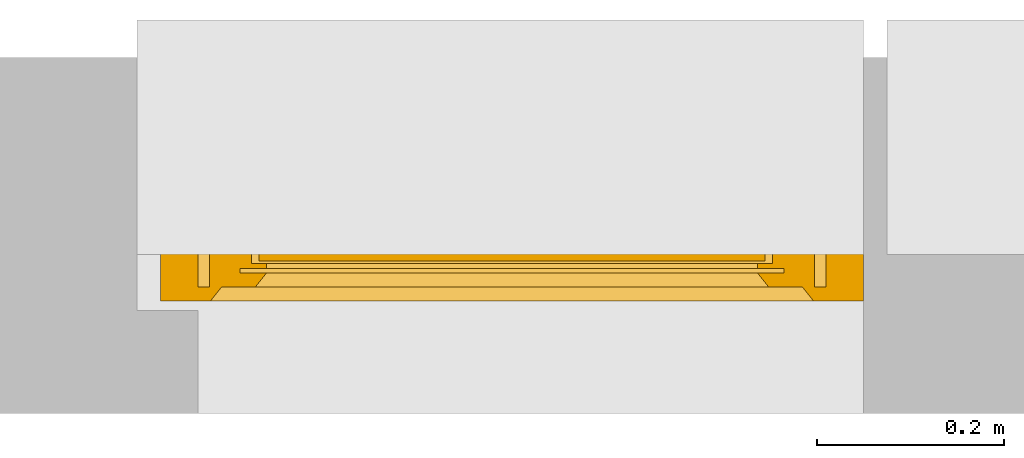
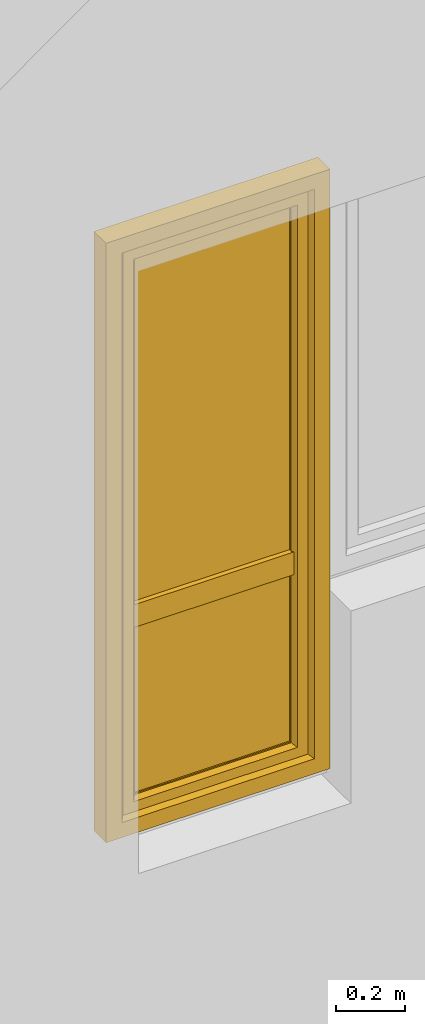
# One storey, part 3 of 4: 1 window.
"""IFC2X3 building model written with IfcOpenShell, lengths in millimetres."""

from ifc_helpers import new_model, entity, si_unit, converted_unit, derived_unit, direction, frame, origin, place, context, subcontext, project, spatial, faceted_brep, source, transform, mapped, material, material_list, type_object, type_shapes, element, save


model = new_model("IFC2X3")

# Units and contexts
model_context = context("Model", 3, precision=0.01, world=origin(), true_north=direction((6.12303176911189e-17, 1.0)))
context_of_model = context(None, 3, precision=0.01, world=origin(), true_north=direction((6.12303176911189e-17, 1.0)))
body_context = subcontext(model_context, "Body", "Model", "MODEL_VIEW")
ifc_project = project(units=[si_unit("LENGTHUNIT", "METRE", prefix="MILLI"), si_unit("AREAUNIT", "SQUARE_METRE"), si_unit("VOLUMEUNIT", "CUBIC_METRE"), converted_unit("PLANEANGLEUNIT", "DEGREE", entity("IfcRatioMeasure", 0.0174532925199433), si_unit("PLANEANGLEUNIT", "RADIAN"), dimensions=[0, 0, 0, 0, 0, 0, 0]), si_unit("MASSUNIT", "GRAM", prefix="KILO"), si_unit("TIMEUNIT", "SECOND"), si_unit("FREQUENCYUNIT", "HERTZ"), si_unit("THERMODYNAMICTEMPERATUREUNIT", "DEGREE_CELSIUS"), derived_unit("THERMALTRANSMITTANCEUNIT", [(si_unit("MASSUNIT", "GRAM", prefix="KILO"), 1), (si_unit("THERMODYNAMICTEMPERATUREUNIT", "KELVIN"), -1), (si_unit("TIMEUNIT", "SECOND"), -3)]), derived_unit("VOLUMETRICFLOWRATEUNIT", [(si_unit("LENGTHUNIT", "METRE"), 3), (si_unit("TIMEUNIT", "SECOND"), -1)]), si_unit("ELECTRICCURRENTUNIT", "AMPERE"), si_unit("ELECTRICVOLTAGEUNIT", "VOLT"), si_unit("POWERUNIT", "WATT"), si_unit("FORCEUNIT", "NEWTON", prefix="KILO"), si_unit("ILLUMINANCEUNIT", "LUX"), si_unit("LUMINOUSFLUXUNIT", "LUMEN"), si_unit("LUMINOUSINTENSITYUNIT", "CANDELA"), si_unit("PRESSUREUNIT", "PASCAL")], contexts=[model_context, context_of_model])

# Site, building, storey
site_placement = place(None, origin())
site = spatial("IfcSite", under=ifc_project, at=site_placement, CompositionType="ELEMENT")
building_placement = place(site_placement, origin())
building = spatial("IfcBuilding", under=site, at=building_placement, CompositionType="ELEMENT")
storey_placement = place(building_placement, origin())
storey = spatial("IfcBuildingStorey", under=building, at=storey_placement, CompositionType="ELEMENT", Elevation=0.0)

# Window
ifc_material_1 = material()
ifc_material_2 = material()
ifc_material_3 = material(Name="Rubber, Black")
ifc_material_4 = material()
ifc_material_5 = material()
ifc_material_list_1 = material_list([ifc_material_1, ifc_material_2, ifc_material_3, ifc_material_4, ifc_material_5])
ifc_material_list_2 = material_list([ifc_material_1, ifc_material_2, ifc_material_3, ifc_material_4, ifc_material_5])
window_style = type_object("IfcWindowStyle", ConstructionType="NOTDEFINED", OperationType="NOTDEFINED", ParameterTakesPrecedence=False, Sizeable=False, material=ifc_material_list_2)
shared_shape = source(origin(), body_context, "Body", "Brep", [
    faceted_brep([(-288.0, -95.0, 1078.0), (-288.0, -95.0, 1042.0), (-288.0, -87.0, 1042.0), (-288.0, -87.0, 1078.0), (-288.843235975199, -87.0, 1082.78534851355), (-288.422218385848, -95.0, 1080.39432433825), (-293.138446626751, -95.0, 1088.56228263263), (-294.997972538787, -87.0, 1090.12318487168), (-295.00101380401, -95.0, 1090.12494091651), (-310.861553373234, -87.0, 1088.56228263264), (-309.002027461198, -95.0, 1090.12318487168), (-308.998986195976, -87.0, 1090.12494091651), (-291.273622272693, -87.0, 1086.99693396951), (-291.275879449492, -95.0, 1086.99962434876), (-290.060158110598, -95.0, 1084.89413651262), (-299.567004156991, -87.0, 1091.78696961731), (-299.570462631182, -95.0, 1091.78757948931), (-297.285738217596, -95.0, 1090.95626020291), (-293.13579740574, -87.0, 1088.5600594206), (-288.844436771704, -95.0, 1082.78864867647), (-290.058429123946, -87.0, 1084.89114124153), (-297.282488347889, -87.0, 1090.9550772445), (-304.429537368803, -87.0, 1091.78757948931), (-304.432995842994, -95.0, 1091.78696961731), (-302.001729237088, -95.0, 1091.78727455331), (-306.717511652096, -95.0, 1090.9550772445), (-306.714261782389, -87.0, 1090.95626020291), (-313.941570876039, -95.0, 1084.89114124153), (-315.155563228281, -87.0, 1082.78864867647), (-315.156764024786, -95.0, 1082.78534851355), (-312.724120550493, -87.0, 1086.99962434876), (-312.726377727292, -95.0, 1086.99693396951), (-310.864202594245, -95.0, 1088.5600594206), (-301.998270762897, -87.0, 1091.78727455331), (-316.0, -95.0, 1078.0), (-315.577781614137, -87.0, 1080.39432433825), (-316.0, -87.0, 1078.0), (-313.939841889387, -87.0, 1084.89413651262), (-316.0, -95.0, 1042.0), (-316.0, -87.0, 1042.0), (-315.156764024786, -95.0, 1037.21465148647), (-315.156764024786, -87.0, 1037.21465148647), (-309.002027461198, -95.0, 1029.87681512833), (-310.864202594245, -95.0, 1031.43994057942), (-312.726377727292, -95.0, 1033.00306603051), (-312.726377727292, -87.0, 1033.00306603051), (-310.864202594245, -87.0, 1031.43994057942), (-309.002027461198, -87.0, 1029.87681512833), (-288.422218385848, -95.0, 1039.60567566177), (-288.844436771704, -95.0, 1037.21135132354), (-288.844436771704, -87.0, 1037.21135132354), (-288.430917360252, -87.0, 1039.55634534639), (-313.941570876039, -87.0, 1035.10885875849), (-313.941570876039, -95.0, 1035.10885875849), (-306.717511652096, -87.0, 1029.04492275552), (-304.432995842994, -87.0, 1028.21303038271), (-304.432995842994, -95.0, 1028.21303038271), (-306.717511652096, -95.0, 1029.04492275552), (-299.570462631183, -95.0, 1028.2124205107), (-302.001729237088, -95.0, 1028.21272544671), (-302.001729237088, -87.0, 1028.21272544671), (-299.570462631183, -87.0, 1028.2124205107), (-297.285738217596, -87.0, 1029.0437397971), (-295.00101380401, -87.0, 1029.8750590835), (-295.00101380401, -95.0, 1029.8750590835), (-297.285738217596, -95.0, 1029.0437397971), (-293.138446626751, -87.0, 1031.43771736738), (-291.275879449492, -87.0, 1033.00037565126), (-291.275879449492, -95.0, 1033.00037565126), (-293.138446626751, -95.0, 1031.43771736738), (-290.060158110598, -87.0, 1035.1058634874), (-290.060158110598, -95.0, 1035.1058634874), (-311.363961030672, -97.0, 1084.3639610307), (-312.242640687112, -97.0, 1082.24264068714), (-313.121320343552, -97.0, 1080.12132034358), (-314.0, -97.0, 1078.0), (-314.0, -97.0, 1042.0), (-313.121320343552, -97.0, 1039.87867965644), (-312.242640687112, -97.0, 1037.75735931288), (-311.363961030672, -97.0, 1035.63603896932), (-310.485281374231, -97.0, 1033.51471862576), (-308.363961030672, -97.0, 1032.63603896932), (-306.242640687112, -97.0, 1031.75735931288), (-304.121320343552, -97.0, 1030.87867965644), (-302.0, -97.0, 1030.0), (-299.878679656433, -97.0, 1030.87867965644), (-297.757359312873, -97.0, 1031.75735931288), (-295.636038969314, -97.0, 1032.63603896932), (-293.514718625754, -97.0, 1033.51471862576), (-292.636038969314, -97.0, 1035.63603896932), (-291.757359312873, -97.0, 1037.75735931288), (-290.878679656433, -97.0, 1039.87867965644), (-290.0, -97.0, 1042.0), (-290.0, -97.0, 1078.0), (-290.878679656433, -97.0, 1080.12132034358), (-291.757359312873, -97.0, 1082.24264068714), (-292.636038969314, -97.0, 1084.3639610307), (-293.514718625754, -97.0, 1086.48528137426), (-295.636038969314, -97.0, 1087.3639610307), (-297.757359312873, -97.0, 1088.24264068714), (-299.878679656433, -97.0, 1089.12132034358), (-302.0, -97.0, 1090.0), (-304.121320343552, -97.0, 1089.12132034358), (-306.242640687112, -97.0, 1088.24264068714), (-308.363961030672, -97.0, 1087.3639610307), (-310.485281374231, -97.0, 1086.48528137426), (-314.0, -85.0, 1078.0), (-313.121320343552, -85.0, 1080.12132034358), (-312.242640687112, -85.0, 1082.24264068714), (-311.363961030672, -85.0, 1084.3639610307), (-310.485281374231, -85.0, 1086.48528137426), (-308.363961030672, -85.0, 1087.3639610307), (-306.242640687112, -85.0, 1088.24264068714), (-304.121320343552, -85.0, 1089.12132034358), (-302.0, -85.0, 1090.0), (-299.878679656433, -85.0, 1089.12132034358), (-297.757359312873, -85.0, 1088.24264068714), (-295.636038969314, -85.0, 1087.3639610307), (-293.514718625754, -85.0, 1086.48528137426), (-292.636038969314, -85.0, 1084.3639610307), (-291.757359312873, -85.0, 1082.24264068714), (-290.878679656433, -85.0, 1080.12132034358), (-290.0, -85.0, 1078.0), (-290.0, -85.0, 1042.0), (-290.878679656433, -85.0, 1039.87867965644), (-291.757359312873, -85.0, 1037.75735931288), (-292.636038969314, -85.0, 1035.63603896932), (-293.514718625754, -85.0, 1033.51471862576), (-295.636038969314, -85.0, 1032.63603896932), (-297.757359312873, -85.0, 1031.75735931288), (-299.878679656433, -85.0, 1030.87867965644), (-302.0, -85.0, 1030.0), (-304.121320343552, -85.0, 1030.87867965644), (-306.242640687112, -85.0, 1031.75735931288), (-308.363961030672, -85.0, 1032.63603896932), (-310.485281374231, -85.0, 1033.51471862576), (-311.363961030672, -85.0, 1035.63603896932), (-312.242640687112, -85.0, 1037.75735931288), (-313.121320343552, -85.0, 1039.87867965644), (-314.0, -85.0, 1042.0)], [[[0, 1, 2, 3]], [[4, 5, 3]], [[6, 7, 8]], [[9, 10, 11]], [[12, 13, 14]], [[15, 16, 17]], [[7, 6, 18]], [[5, 0, 3]], [[18, 6, 13]], [[14, 19, 20]], [[4, 19, 5]], [[15, 17, 21]], [[8, 21, 17]], [[12, 14, 20]], [[22, 23, 24]], [[25, 11, 10]], [[26, 23, 22]], [[27, 28, 29]], [[21, 8, 7]], [[20, 19, 4]], [[30, 31, 32]], [[33, 16, 15]], [[34, 35, 36]], [[11, 25, 26]], [[23, 26, 25]], [[37, 27, 31]], [[32, 10, 9]], [[29, 28, 35]], [[30, 32, 9]], [[34, 29, 35]], [[28, 27, 37]], [[18, 13, 12]], [[33, 24, 16]], [[37, 31, 30]], [[22, 24, 33]], [[38, 34, 36, 39]], [[40, 38, 39, 41]], [[42, 43, 44, 45, 46, 47]], [[2, 1, 48, 49, 50, 51]], [[41, 52, 45, 44, 53, 40]], [[47, 54, 55, 56, 57, 42]], [[58, 59, 56, 55, 60, 61]], [[61, 62, 63, 64, 65, 58]], [[66, 67, 68, 69, 64, 63]], [[67, 70, 50, 49, 71, 68]], [[72, 73, 74, 75, 76, 77, 78, 79, 80, 81, 82, 83, 84, 85, 86, 87, 88, 89, 90, 91, 92, 93, 94, 95, 96, 97, 98, 99, 100, 101, 102, 103, 104, 105]], [[92, 48, 1]], [[48, 92, 91]], [[71, 49, 90]], [[44, 79, 53]], [[90, 49, 91]], [[78, 40, 53]], [[88, 68, 89]], [[88, 69, 68]], [[69, 87, 64]], [[89, 68, 71]], [[82, 57, 83]], [[91, 49, 48]], [[65, 85, 58]], [[82, 42, 57]], [[56, 84, 83]], [[65, 64, 86]], [[56, 83, 57]], [[76, 38, 77]], [[58, 84, 56, 59]], [[80, 44, 43]], [[85, 65, 86]], [[40, 77, 38]], [[82, 81, 42]], [[40, 78, 77]], [[43, 81, 80]], [[71, 90, 89]], [[87, 69, 88]], [[79, 44, 80]], [[79, 78, 53]], [[87, 86, 64]], [[85, 84, 58]], [[43, 42, 81]], [[92, 1, 0, 93]], [[72, 31, 27]], [[34, 74, 29]], [[27, 29, 73]], [[13, 96, 14]], [[74, 73, 29]], [[95, 19, 14]], [[104, 32, 105]], [[105, 32, 31]], [[32, 104, 10]], [[105, 31, 72]], [[99, 17, 100]], [[74, 34, 75]], [[25, 102, 23]], [[99, 8, 17]], [[16, 101, 100]], [[25, 10, 103]], [[16, 100, 17]], [[5, 93, 0]], [[99, 98, 8]], [[97, 13, 6]], [[93, 5, 94]], [[102, 25, 103]], [[94, 5, 19]], [[24, 23, 101, 16]], [[27, 73, 72]], [[96, 13, 97]], [[6, 98, 97]], [[96, 95, 14]], [[104, 103, 10]], [[102, 101, 23]], [[6, 8, 98]], [[94, 19, 95]], [[75, 34, 38, 76]], [[106, 107, 108, 109, 110, 111, 112, 113, 114, 115, 116, 117, 118, 119, 120, 121, 122, 123, 124, 125, 126, 127, 128, 129, 130, 131, 132, 133, 134, 135, 136, 137, 138, 139]], [[136, 45, 52]], [[39, 138, 41]], [[52, 41, 137]], [[67, 126, 70]], [[138, 137, 41]], [[125, 50, 70]], [[134, 46, 135]], [[135, 46, 45]], [[46, 134, 47]], [[135, 45, 136]], [[129, 62, 130]], [[138, 39, 139]], [[54, 132, 55]], [[129, 63, 62]], [[61, 131, 130]], [[54, 47, 133]], [[61, 130, 62]], [[51, 123, 2]], [[129, 128, 63]], [[127, 67, 66]], [[123, 51, 124]], [[132, 54, 133]], [[124, 51, 50]], [[60, 55, 131, 61]], [[52, 137, 136]], [[126, 67, 127]], [[66, 128, 127]], [[126, 125, 70]], [[134, 133, 47]], [[132, 131, 55]], [[66, 63, 128]], [[124, 50, 125]], [[122, 3, 2, 123]], [[119, 12, 20]], [[3, 121, 4]], [[20, 4, 120]], [[30, 109, 37]], [[121, 120, 4]], [[108, 28, 37]], [[117, 18, 118]], [[118, 18, 12]], [[18, 117, 7]], [[118, 12, 119]], [[112, 26, 113]], [[121, 3, 122]], [[21, 115, 15]], [[112, 11, 26]], [[22, 114, 113]], [[21, 7, 116]], [[22, 113, 26]], [[35, 106, 36]], [[112, 111, 11]], [[110, 30, 9]], [[106, 35, 107]], [[115, 21, 116]], [[107, 35, 28]], [[33, 15, 114, 22]], [[20, 120, 119]], [[109, 30, 110]], [[9, 111, 110]], [[109, 108, 37]], [[117, 116, 7]], [[115, 114, 15]], [[9, 11, 111]], [[107, 28, 108]], [[139, 39, 36, 106]]]),
    faceted_brep([(-307.291502622106, -145.276775255392, 1000.52114796616), (-296.708497377848, -145.276775255392, 1000.52114796616), (-296.708497377848, -140.837885234757, 1042.66882878318), (-307.291502622106, -140.837885234757, 1042.66882878318), (-294.516685226428, -136.448348130646, 1000.52114796616), (-294.516685226428, -132.203155672521, 1040.82965209673), (-302.0, -131.276775255392, 1000.52114796616), (-302.0, -127.145048202385, 1039.75228733741), (-309.483314773524, -136.448348130645, 1000.52114796616), (-309.483314773524, -132.203155672519, 1040.82965209673), (-307.291502622106, -140.837885234758, 958.373467149146), (-296.708497377848, -140.837885234758, 958.373467149147), (-294.516685226428, -132.203155672521, 960.212643835597), (-302.0, -127.145048202386, 961.29000859492), (-309.483314773524, -132.20315567252, 960.212643835597)], [[[0, 1, 2, 3]], [[1, 4, 5, 2]], [[4, 6, 7, 5]], [[6, 8, 9, 7]], [[8, 0, 3, 9]], [[10, 11, 1, 0]], [[11, 12, 4, 1]], [[12, 13, 6, 4]], [[13, 14, 8, 6]], [[14, 10, 0, 8]], [[3, 2, 5, 7, 9]], [[14, 13, 12, 11, 10]]]),
    faceted_brep([(-311.948919316965, -97.0, 1060.94591729901), (-311.388304441298, -97.0, 1063.43924096907), (-310.210737936944, -97.0, 1065.70333478471), (-308.494826146008, -97.0, 1067.59726390535), (-306.358898943517, -97.0, 1069.0), (-302.0, -97.0, 1069.0), (-297.641101056436, -97.0, 1069.0), (-295.505173853945, -97.0, 1067.59726390535), (-293.78926206301, -97.0, 1065.70333478471), (-292.611695558656, -97.0, 1063.43924096907), (-292.051080682988, -97.0, 1060.94591729901), (-292.13090453415, -97.0, 1058.3919203214), (-292.862798628599, -97.0, 1055.94604186494), (-294.190544488105, -97.0, 1053.7614130413), (-296.022965207414, -97.0, 1051.98307257928), (-298.251994222266, -97.0, 1050.73512735946), (-300.723700590378, -97.0, 1050.08403873227), (-303.276299409575, -97.0, 1050.08403873227), (-305.748005777687, -97.0, 1050.73512735946), (-307.977034792539, -97.0, 1051.98307257928), (-309.809455511849, -97.0, 1053.7614130413), (-311.137201371354, -97.0, 1055.94604186494), (-311.869095465803, -97.0, 1058.3919203214), (-308.630084186039, -139.571199871011, 1041.81582813483), (-309.544657376314, -138.066781139833, 1040.80273507336), (-309.969670400814, -136.42046719477, 1039.69408812541), (-309.881729331265, -134.736601923398, 1038.56015367782), (-309.28801801609, -133.126161127661, 1037.47566412563), (-308.220022030302, -131.692818084303, 1036.51043425854), (-306.755121821292, -130.525776486187, 1035.72453488026), (-304.981030164164, -129.706502117789, 1035.17282599704), (-303.015004374953, -129.280982287031, 1034.88627599661), (-300.984995625, -129.280982287031, 1034.88627599661), (-299.018969835788, -129.706502117789, 1035.17282599704), (-297.244878178661, -130.525776486188, 1035.72453488026), (-295.779977969651, -131.692818084303, 1036.51043425854), (-294.711981983863, -133.126161127661, 1037.47566412563), (-294.118270668688, -134.736601923398, 1038.56015367782), (-294.030329599139, -136.420467194771, 1039.69408812541), (-294.455342623639, -138.066781139833, 1040.80273507336), (-295.369915813914, -139.571199871011, 1041.81582813483), (-296.708497377848, -140.838667192924, 1042.6693553629), (-300.206894448272, -140.838667192924, 1042.6693553629), (-303.749198535189, -140.838667192924, 1042.6693553629), (-307.291502622106, -140.838667192924, 1042.6693553629), (-299.470501119522, -126.416323041036, 1058.53479166182), (-302.0, -123.592503743986, 1060.46960324719), (-301.978047137813, -133.930955778539, 1051.86725150298), (-296.827409391356, -136.56784382523, 1047.7486255059), (-299.246224213147, -134.00299976312, 1051.79007956711), (-304.379075047105, -127.567125778351, 1057.66721198755), (-304.23715734297, -119.178161613072, 1063.00337884315), (-306.980634729243, -129.673589570168, 1055.9479296637), (-304.841946810805, -134.921809886446, 1050.7785343575), (-303.031674795436, -110.940739168215, 1066.41174131507), (-306.66976683638, -114.56747742195, 1065.10298096761), (-299.907940881426, -106.916614530037, 1067.54270145077), (-297.01936527071, -129.673589570169, 1055.9479296637), (-297.330233163573, -114.56747742195, 1065.10298096761), (-293.665547370106, -129.075791149345, 1045.92276589624), (-293.132073829399, -116.519842499668, 1058.07942490617), (-292.540900854049, -107.240572966488, 1060.08550854294), (-298.085967686742, -125.260625550182, 1040.68801313964), (-296.380283644659, -120.444255008249, 1045.78506579307), (-308.974790089265, -123.255273619451, 1045.70424775683), (-311.017716519097, -115.101506888561, 1058.22389640407), (-308.818882821001, -112.022437290098, 1050.92399318817), (-295.15596584972, -109.417405225703, 1051.67364545902), (-293.264592593691, -123.544355953025, 1052.17506192804), (-311.306850420164, -106.118963862214, 1056.84627828438), (-304.52980153325, -104.684687559105, 1049.97313305255)], [[[0, 1, 2, 3, 4, 5, 6, 7, 8, 9, 10, 11, 12, 13, 14, 15, 16, 17, 18, 19, 20, 21, 22]], [[23, 24, 25, 26, 27, 28, 29, 30, 31, 32, 33, 34, 35, 36, 37, 38, 39, 40, 41, 42, 43, 44]], [[45, 46, 47]], [[42, 41, 48]], [[49, 45, 47]], [[50, 46, 51]], [[50, 51, 52]], [[43, 47, 53]], [[53, 50, 52]], [[54, 4, 55]], [[44, 43, 53]], [[56, 6, 5]], [[48, 49, 42]], [[42, 47, 43]], [[49, 48, 57]], [[5, 54, 56]], [[49, 57, 45]], [[42, 49, 47]], [[57, 58, 45]], [[58, 46, 45]], [[50, 47, 46]], [[44, 53, 52]], [[47, 50, 53]], [[46, 54, 51]], [[56, 46, 58]], [[4, 54, 5]], [[54, 55, 51]], [[52, 51, 55]], [[46, 56, 54]], [[6, 56, 58]], [[40, 59, 41]], [[39, 38, 59]], [[59, 40, 39]], [[36, 59, 37]], [[60, 61, 58]], [[35, 34, 62]], [[62, 59, 36]], [[59, 62, 63]], [[33, 62, 34]], [[35, 62, 36]], [[38, 37, 59]], [[9, 8, 61]], [[61, 10, 9]], [[64, 65, 66]], [[8, 7, 61]], [[58, 7, 6]], [[58, 61, 7]], [[63, 67, 68]], [[67, 13, 61]], [[52, 55, 65]], [[67, 60, 68]], [[31, 62, 32]], [[59, 68, 57]], [[13, 67, 14]], [[65, 69, 66]], [[10, 61, 11]], [[11, 61, 12]], [[69, 55, 1]], [[16, 70, 17]], [[33, 32, 62]], [[66, 67, 63]], [[69, 70, 66]], [[67, 66, 70]], [[70, 15, 67]], [[29, 64, 30]], [[27, 64, 28]], [[64, 29, 28]], [[65, 64, 52]], [[25, 24, 64]], [[57, 60, 58]], [[64, 24, 52]], [[23, 44, 52]], [[67, 61, 60]], [[23, 52, 24]], [[64, 26, 25]], [[69, 65, 55]], [[63, 64, 66]], [[69, 20, 19]], [[69, 21, 20]], [[61, 13, 12]], [[60, 57, 68]], [[70, 16, 15]], [[17, 70, 18]], [[68, 59, 63]], [[62, 64, 63]], [[19, 18, 70]], [[69, 1, 0]], [[0, 22, 69]], [[1, 55, 2]], [[30, 62, 31]], [[64, 27, 26]], [[3, 2, 55]], [[4, 3, 55]], [[19, 70, 69]], [[15, 14, 67]], [[21, 69, 22]], [[59, 57, 48, 41]], [[64, 62, 30]]]),
    faceted_brep([(323.0, -15.0, 2068.0), (323.0, -70.0, 2068.0), (323.0, -70.0, 52.0), (323.0, -15.0, 52.0), (262.000081964466, -30.0, 2007.00008196447), (274.0, -15.0, 2019.0), (274.0, -15.0, 101.0), (262.000081964466, -30.0, 112.999918035527), (290.0, -72.0, 2035.0), (290.0, -30.0, 2035.0), (290.0, -30.0, 85.0), (290.0, -72.0, 85.0), (274.0, -84.0, 2019.0), (262.0, -72.0, 2007.0), (262.0, -72.0, 113.0), (274.0, -84.0, 101.0), (287.0, -85.0, 2032.0), (287.0, -84.0, 2032.0), (287.0, -84.0, 88.0), (287.0, -85.0, 88.0), (343.0, -83.0, 2088.0), (341.0, -85.0, 2086.0), (341.0, -85.0, 34.0), (343.0, -83.0, 32.0), (343.0, -70.0, 2088.0), (343.0, -70.0, 32.0), (-323.0, -70.0, 52.0), (-323.0, -15.0, 52.0), (-274.0, -15.0, 101.0), (-262.00008196447, -30.0, 112.999918035527), (-290.0, -30.0, 85.0), (-290.0, -72.0, 85.0), (-262.0, -72.0, 113.0), (-274.0, -84.0, 101.0), (-287.0, -84.0, 88.0), (-287.0, -85.0, 88.0), (-341.0, -85.0, 34.0), (-343.0, -83.0, 32.0), (-343.0, -70.0, 32.0), (-323.0, -70.0, 2068.0), (-323.0, -15.0, 2068.0), (-274.0, -15.0, 2019.0), (-262.00008196447, -30.0, 2007.00008196447), (-290.0, -30.0, 2035.0), (-290.0, -72.0, 2035.0), (-262.0, -72.0, 2007.0), (-274.0, -84.0, 2019.0), (-287.0, -84.0, 2032.0), (-287.0, -85.0, 2032.0), (-341.0, -85.0, 2086.0), (-343.0, -83.0, 2088.0), (-343.0, -70.0, 2088.0)], [[[0, 1, 2, 3]], [[4, 5, 6, 7]], [[8, 9, 10, 11]], [[12, 13, 14, 15]], [[16, 17, 18, 19]], [[20, 21, 22, 23]], [[24, 20, 23, 25]], [[3, 2, 26, 27]], [[7, 6, 28, 29]], [[11, 10, 30, 31]], [[15, 14, 32, 33]], [[19, 18, 34, 35]], [[23, 22, 36, 37]], [[25, 23, 37, 38]], [[27, 26, 39, 40]], [[29, 28, 41, 42]], [[31, 30, 43, 44]], [[33, 32, 45, 46]], [[35, 34, 47, 48]], [[37, 36, 49, 50]], [[38, 37, 50, 51]], [[40, 39, 1, 0]], [[3, 27, 40, 0], [5, 41, 28, 6]], [[42, 41, 5, 4]], [[7, 29, 42, 4], [9, 43, 30, 10]], [[44, 43, 9, 8]], [[11, 31, 44, 8], [13, 45, 32, 14]], [[46, 45, 13, 12]], [[15, 33, 46, 12], [17, 47, 34, 18]], [[48, 47, 17, 16]], [[19, 35, 48, 16], [21, 49, 36, 22]], [[50, 49, 21, 20]], [[51, 50, 20, 24]], [[1, 39, 26, 2], [25, 38, 51, 24]]], outer=[[True], [True], [True], [True], [True], [True], [True], [True], [True], [True], [True], [True], [True], [True], [True], [True], [True], [True], [True], [True], [True], [True], [True, False], [True], [False, True], [True], [True, False], [True], [False, True], [True], [False, True], [True], [True], [False, True]]),
    faceted_brep([(-290.0, -67.0, 85.0), (-290.0, -35.0, 85.0), (290.0, -35.0, 85.0), (290.0, -67.0, 85.0), (-262.0, -62.0, 113.0), (-262.0, -67.0, 113.0), (262.0, -67.0, 113.0), (262.0, -62.0, 113.0), (-278.0, -40.0, 97.0), (-278.0, -62.0, 97.0), (278.0, -62.0, 97.0), (278.0, -40.0, 97.0), (-262.0, -35.0, 113.0), (-262.0, -40.0, 113.0), (262.0, -40.0, 113.0), (262.0, -35.0, 113.0), (290.0, -35.0, 2035.0), (290.0, -67.0, 2035.0), (262.0, -67.0, 2007.0), (262.0, -62.0, 2007.0), (278.0, -62.0, 2023.0), (278.0, -40.0, 2023.0), (262.0, -40.0, 2007.0), (262.0, -35.0, 2007.0), (-290.0, -35.0, 2035.0), (-290.0, -67.0, 2035.0), (-262.0, -67.0, 2007.0), (-262.0, -62.0, 2007.0), (-278.0, -62.0, 2023.0), (-278.0, -40.0, 2023.0), (-262.0, -40.0, 2007.0), (-262.0, -35.0, 2007.0)], [[[0, 1, 2, 3]], [[4, 5, 6, 7]], [[8, 9, 10, 11]], [[12, 13, 14, 15]], [[3, 2, 16, 17]], [[7, 6, 18, 19]], [[11, 10, 20, 21]], [[15, 14, 22, 23]], [[17, 16, 24, 25]], [[19, 18, 26, 27]], [[21, 20, 28, 29]], [[23, 22, 30, 31]], [[15, 23, 31, 12], [1, 24, 16, 2]], [[25, 24, 1, 0]], [[3, 17, 25, 0], [5, 26, 18, 6]], [[27, 26, 5, 4]], [[7, 19, 27, 4], [9, 28, 20, 10]], [[29, 28, 9, 8]], [[11, 21, 29, 8], [13, 30, 22, 14]], [[31, 30, 13, 12]]], outer=[[True], [True], [True], [True], [True], [True], [True], [True], [True], [True], [True], [True], [False, True], [True], [True, False], [True], [False, True], [True], [True, False], [True]]),
    faceted_brep([(270.0, -65.0, 105.0), (270.0, -65.0, 710.0), (-270.0, -65.0, 710.0), (-270.0, -65.0, 105.0), (270.0, -43.0, 105.0), (-270.0, -43.0, 105.0), (-270.0, -43.0, 710.0), (270.0, -43.0, 710.0)], [[[0, 1, 2, 3]], [[4, 5, 6, 7]], [[1, 0, 4, 7]], [[2, 1, 7, 6]], [[3, 2, 6, 5]], [[0, 3, 5, 4]]]),
    faceted_brep([(-270.0, -62.0, 2019.0), (-270.0, -62.0, 770.0), (274.0, -62.0, 770.0), (274.0, -62.0, 2019.0), (-270.0, -40.0, 2019.0), (274.0, -40.0, 2019.0), (274.0, -40.0, 770.0), (-270.0, -40.0, 770.0)], [[[0, 1, 2, 3]], [[4, 5, 6, 7]], [[1, 0, 4, 7]], [[2, 1, 7, 6]], [[3, 2, 6, 5]], [[0, 3, 5, 4]]]),
    faceted_brep([(270.0, -23.0, 710.0), (270.0, -23.0, 790.0), (270.0, -85.0, 790.0), (270.0, -85.0, 710.0), (-270.0, -23.0, 790.0), (-270.0, -23.0, 710.0), (-270.0, -85.0, 710.0), (-270.0, -85.0, 790.0)], [[[0, 1, 2, 3]], [[4, 5, 6, 7]], [[2, 1, 4, 7]], [[2, 7, 6, 3]], [[0, 3, 6, 5]], [[0, 5, 4, 1]]]),
    faceted_brep([(-375.0, -70.0, 2120.0), (-375.0, 0.0, 2120.0), (-375.0, 0.0, 0.0), (-375.0, -70.0, 0.0), (-335.0, -15.0, 2080.0), (-335.0, -70.0, 2080.0), (-335.0, -70.0, 40.0), (-335.0, -15.0, 40.0), (-322.0, 0.0, 2067.0), (-310.0, -15.0, 2055.0), (-310.0, -15.0, 65.0), (-322.0, 0.0, 53.0), (375.0, 0.0, 0.0), (375.0, -70.0, 0.0), (335.0, -70.0, 40.0), (335.0, -15.0, 40.0), (310.0, -15.0, 65.0), (322.0, 0.0, 53.0), (375.0, 0.0, 2120.0), (375.0, -70.0, 2120.0), (335.0, -70.0, 2080.0), (335.0, -15.0, 2080.0), (310.0, -15.0, 2055.0), (322.0, 0.0, 2067.0)], [[[0, 1, 2, 3]], [[4, 5, 6, 7]], [[8, 9, 10, 11]], [[3, 2, 12, 13]], [[7, 6, 14, 15]], [[11, 10, 16, 17]], [[13, 12, 18, 19]], [[15, 14, 20, 21]], [[17, 16, 22, 23]], [[11, 17, 23, 8], [1, 18, 12, 2]], [[19, 18, 1, 0]], [[3, 13, 19, 0], [5, 20, 14, 6]], [[21, 20, 5, 4]], [[7, 15, 21, 4], [9, 22, 16, 10]], [[23, 22, 9, 8]]], outer=[[True], [True], [True], [True], [True], [True], [True], [True], [True], [False, True], [True], [True, False], [True], [True, False], [True]]),
])
type_shapes(window_style, [shared_shape])
window_placement = place(storey_placement, frame((-16379.8270290103, 12473.5585138251, 850.0), z_axis=(0.0, 0.0, 1.0), x_axis=(-1.0, 0.0, 0.0)))
element("IfcWindow", 1, at=window_placement, inside=storey, type_object=window_style, material=ifc_material_list_1, OverallHeight=2120.0, OverallWidth=910.000000000007, context=body_context, shape_type="MappedRepresentation", body=[
    mapped(shared_shape, transform((0.0, 0.0, 0.0), scale=1.0)),
])

save(model, "model.ifc")
